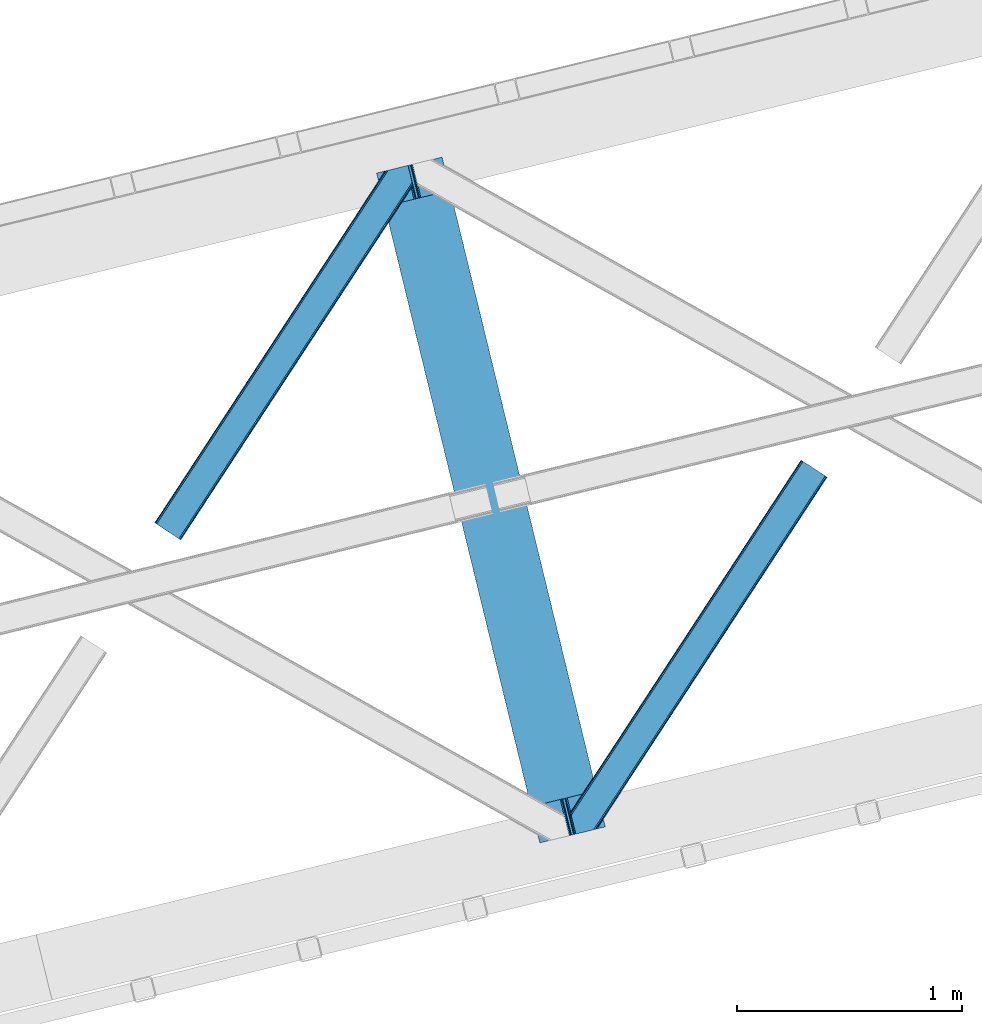
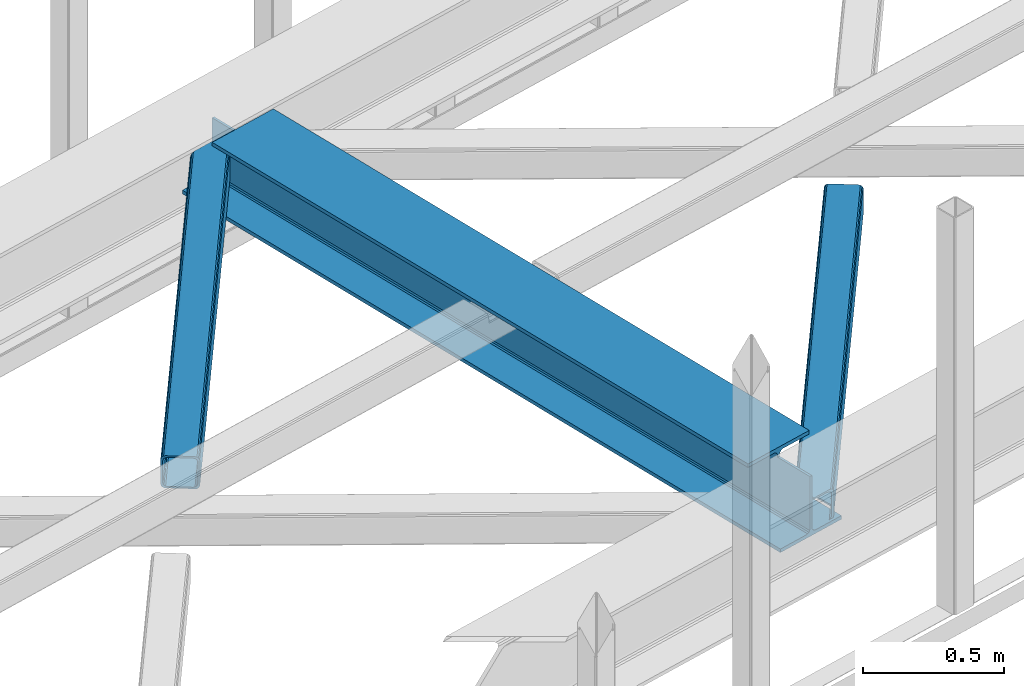
# One storey, part 31 of 67: 2 members, 1 beam.
"""IFC4 building model written with IfcOpenShell, lengths in millimetres."""

from ifc_helpers import new_model, entity, si_unit, converted_unit, derived_unit, direction, frame, origin, place, context, subcontext, project, spatial, triangles, polygons, material, type_object, element, save


model = new_model("IFC4")

# Units and contexts
model_context = context("Model", 3, precision=0.01, world=origin(), true_north=direction((6.12303176911189e-17, 1.0)))
plan_context = context("Plan", 3, precision=0.01, world=origin(), true_north=direction((6.12303176911189e-17, 1.0)))
body_context = subcontext(model_context, "Body", "Model", "MODEL_VIEW")
ifc_project = project(units=[si_unit("LENGTHUNIT", "METRE", prefix="MILLI"), si_unit("AREAUNIT", "SQUARE_METRE"), si_unit("VOLUMEUNIT", "CUBIC_METRE"), converted_unit("PLANEANGLEUNIT", "DEGREE", entity("IfcRatioMeasure", 0.0174532925199433), si_unit("PLANEANGLEUNIT", "RADIAN"), dimensions=[0, 0, 0, 0, 0, 0, 0]), si_unit("MASSUNIT", "GRAM", prefix="KILO"), derived_unit("MASSDENSITYUNIT", [(si_unit("MASSUNIT", "GRAM", prefix="KILO"), 1), (si_unit("LENGTHUNIT", "METRE"), -3)]), derived_unit("MOMENTOFINERTIAUNIT", [(si_unit("LENGTHUNIT", "METRE"), 4)]), si_unit("TIMEUNIT", "SECOND"), si_unit("FREQUENCYUNIT", "HERTZ"), si_unit("THERMODYNAMICTEMPERATUREUNIT", "DEGREE_CELSIUS"), derived_unit("THERMALTRANSMITTANCEUNIT", [(si_unit("MASSUNIT", "GRAM", prefix="KILO"), 1), (si_unit("THERMODYNAMICTEMPERATUREUNIT", "KELVIN"), -1), (si_unit("TIMEUNIT", "SECOND"), -3)]), derived_unit("VOLUMETRICFLOWRATEUNIT", [(si_unit("LENGTHUNIT", "METRE"), 3), (si_unit("TIMEUNIT", "SECOND"), -1)]), derived_unit("MASSFLOWRATEUNIT", [(si_unit("MASSUNIT", "GRAM", prefix="KILO"), 1), (si_unit("TIMEUNIT", "SECOND"), -1)]), derived_unit("ROTATIONALFREQUENCYUNIT", [(si_unit("TIMEUNIT", "SECOND"), -1)]), si_unit("ELECTRICCURRENTUNIT", "AMPERE"), si_unit("ELECTRICVOLTAGEUNIT", "VOLT"), si_unit("POWERUNIT", "WATT"), si_unit("FORCEUNIT", "NEWTON", prefix="KILO"), si_unit("ILLUMINANCEUNIT", "LUX"), si_unit("LUMINOUSFLUXUNIT", "LUMEN"), si_unit("LUMINOUSINTENSITYUNIT", "CANDELA"), derived_unit("USERDEFINED", [(si_unit("MASSUNIT", "GRAM", prefix="KILO"), -1), (si_unit("LENGTHUNIT", "METRE"), -2), (si_unit("TIMEUNIT", "SECOND"), 3), (si_unit("LUMINOUSFLUXUNIT", "LUMEN"), 1)]), derived_unit("LINEARVELOCITYUNIT", [(si_unit("LENGTHUNIT", "METRE"), 1), (si_unit("TIMEUNIT", "SECOND"), -1)]), si_unit("PRESSUREUNIT", "PASCAL"), derived_unit("USERDEFINED", [(si_unit("LENGTHUNIT", "METRE"), -2), (si_unit("MASSUNIT", "GRAM", prefix="KILO"), 1), (si_unit("TIMEUNIT", "SECOND"), -2)]), derived_unit("LINEARFORCEUNIT", [(si_unit("MASSUNIT", "GRAM", prefix="KILO"), 1), (si_unit("LENGTHUNIT", "METRE"), 1), (si_unit("TIMEUNIT", "SECOND"), -2), (si_unit("LENGTHUNIT", "METRE"), -1)]), derived_unit("PLANARFORCEUNIT", [(si_unit("MASSUNIT", "GRAM", prefix="KILO"), 1), (si_unit("LENGTHUNIT", "METRE"), 1), (si_unit("TIMEUNIT", "SECOND"), -2), (si_unit("LENGTHUNIT", "METRE"), -2)])], contexts=[model_context, plan_context])

# Site, building, storey
site_placement = place(None, origin())
site = spatial("IfcSite", under=ifc_project, at=site_placement, CompositionType="ELEMENT")
building_placement = place(site_placement, origin())
building = spatial("IfcBuilding", under=site, at=building_placement, CompositionType="ELEMENT")
storey_placement = place(building_placement, frame((0.0, 0.0, 19800.0)))
storey = spatial("IfcBuildingStorey", under=building, at=storey_placement, CompositionType="ELEMENT", Elevation=19800.0)

# Beam
ifc_material = material(Name="Metal painted (White)")
beam_type = type_object("IfcBeamType", PredefinedType="BEAM")
beam_placement = place(storey_placement, frame((-39874.8174225065, 8075.02059865561, 3807.02022389142)))
element("IfcBeam", 1, at=beam_placement, inside=storey, type_object=beam_type, material=ifc_material, ObjectType="Steel Beam", PredefinedType="BEAM", context=body_context, shape_type="Tessellation", body=[
    polygons([(1018.16648378329, 71.0478278971021, 15.5000000000008), (1018.16648378329, 71.0478278971021, 0.0), (291.465617442446, 3052.25531830421, 0.0), (291.465617442446, 3052.25531830421, 15.5000000000008), (894.779372399329, 40.9709140873291, 15.5000000000008), (168.078506058474, 3022.17840449444, 15.5000000000008), (888.087028625371, 39.3395844888243, 16.8701684147984), (161.386162284528, 3020.54707489593, 16.8701684147984), (882.413533524751, 37.9566100336508, 20.7720779386434), (155.712667183895, 3019.16410044076, 20.7720779386434), (878.622625296176, 37.0325360459151, 26.6116982174294), (151.921758955329, 3018.24002645303, 26.6116982174294), (877.291435352788, 36.7080444135018, 33.500000000001), (150.590569011932, 3017.91553482061, 33.500000000001), (140.875048430514, 3015.54727389071, 33.500000000001), (140.875048430514, 3015.54727389071, 259.000000000002), (150.590569011932, 3017.91553482061, 259.000000000002), (8.66293703438714e-12, 2981.20749040711, 0.0), (8.66293703438714e-12, 2981.20749040711, 15.4999999999965), (123.387111383972, 3011.28440421689, 15.5000000000008), (130.079455157926, 3012.91573381539, 16.8701684147984), (135.752950258551, 3014.29870827056, 20.7720779386434), (139.543858487117, 3015.22278225829, 26.6116982174294), (877.291435352783, 36.7080444135018, 259.000000000002), (867.575914771365, 34.3397834835981, 259.000000000002), (867.575914771365, 34.339783483597, 33.500000000001), (866.244724827968, 34.0152918511827, 26.6116982174294), (862.453816599397, 33.0912178634492, 20.7720779386434), (856.780321498782, 31.7082434082767, 16.8701684147984), (850.087977724828, 30.0769138097719, 15.5000000000008), (726.700866340855, 0.0, 15.4999999999965), (726.700866340855, 0.0, 0.0), (838.124523615921, 197.385937999179, 259.069791973884), (186.469722099971, 2870.72539801218, 259.000000000002), (186.69311520182, 2869.80895360721, 259.617303331124), (186.705504045446, 2869.75812937344, 266.500003008253), (837.979344808156, 197.981416001702, 266.500002998871), (837.979694928899, 197.979979696968, 260.000004007589), (828.499586345876, 194.64586594443, 259.006343171919), (828.276216326111, 195.56231748191, 259.617303331124), (828.263827482486, 195.613141715684, 266.500003008253), (176.989986719784, 2867.38985508742, 266.500002998871), (176.989636599032, 2867.39129139215, 260.000004007589), (176.844830940696, 2867.98534020594, 259.07612046749), (176.754201518561, 2868.35713708228, 259.000000000002), (839.310832678066, 198.304685446387, 273.388305639783), (843.10110926677, 199.231350618301, 279.227924098781), (848.774180214309, 200.616065081978, 283.129832400615), (855.466371895434, 202.248018612792, 284.500000377228), (978.853400583269, 232.3252716679, 284.500000138971), (978.851730776613, 232.332121736634, 299.999995328161), (687.386308679356, 161.283492472592, 299.999995890962), (687.387978486008, 161.27664240386, 284.500000701776), (810.775007173852, 191.353895458971, 284.500000463519), (817.467494069982, 192.984637925549, 283.129832461069), (823.141405718751, 194.365903570074, 279.227924137322), (826.932940505742, 195.28740721937, 273.388305663684), (175.658498849857, 2867.06658564273, 273.388305639788), (171.868222261161, 2866.13992047082, 279.227924098781), (166.195151313631, 2864.75520600714, 283.129832400619), (159.502959632506, 2863.12325247633, 284.500000377228), (36.115930944662, 2833.04599942122, 284.500000138971), (36.1176007513137, 2833.03914935249, 299.999995328161), (327.583022848575, 2904.08777861653, 299.999995890962), (327.581353041924, 2904.09462868526, 284.500000701776), (204.19432435408, 2874.01737563015, 284.500000463519), (197.501837457932, 2872.38663316357, 283.129832461065), (191.827925809181, 2871.00536751905, 279.227924137322), (188.03639102218, 2870.08386386975, 273.388305663684)], [[[1, 2, 3, 4]], [[5, 1, 4, 6]], [[7, 5, 6, 8]], [[9, 7, 8, 10]], [[11, 9, 10, 12]], [[13, 11, 12, 14]], [[15, 16, 17, 14, 12, 10, 8, 6, 4, 3, 18, 19, 20, 21, 22, 23]], [[13, 24, 25, 26, 27, 28, 29, 30, 31, 32, 2, 1, 5, 7, 9, 11]], [[2, 32, 18, 3]], [[32, 31, 19, 18]], [[31, 30, 20, 19]], [[27, 26, 15, 23]], [[28, 27, 23, 22]], [[29, 28, 22, 21]], [[30, 29, 21, 20]], [[33, 24, 13, 14, 17, 34, 35, 36, 37, 38]], [[25, 39, 40, 41, 42, 43, 44, 16, 15, 26]], [[39, 25, 24, 33]], [[45, 34, 17, 16]], [[41, 40, 38, 37, 46, 47, 48, 49, 50, 51, 52, 53, 54, 55, 56, 57]], [[42, 58, 59, 60, 61, 62, 63, 64, 65, 66, 67, 68, 69, 36, 35, 43]], [[46, 37, 36, 69]], [[47, 46, 69, 68]], [[48, 47, 68, 67]], [[49, 48, 67, 66]], [[50, 49, 66, 65]], [[51, 50, 65, 64]], [[52, 51, 64, 63]], [[53, 52, 63, 62]], [[54, 53, 62, 61]], [[55, 54, 61, 60]], [[56, 55, 60, 59]], [[57, 56, 59, 58]], [[41, 57, 58, 42]]], closed=False),
])

# Members
member_type_1 = type_object("IfcMemberType", PredefinedType="BRACE")
member_1_placement = place(storey_placement, frame((-40863.0220458984, 9423.02541046143, 3823.99987792968)))
element("IfcMember", 2, at=member_1_placement, inside=storey, type_object=member_type_1, ObjectType="Steel Horizontal Brace", PredefinedType="BRACE", context=body_context, shape_type="Tessellation", body=[
    triangles([(994.776489257813, 1564.02720794678, 0.0), (1028.82557373047, 1424.34736175537, 0.0), (14.6409667968765, 67.1040435791001, 0.0), (102.486767578128, 9.58604278564417, 0.0), (1.1162109375, 75.9604797363281, 10.8039916992202), (0.0, 76.6900863647461, 17.5012573242202), (1025.02580566407, 1642.17825164795, 17.5012573242202), (4.28811035156104, 73.8821182250977, 5.12526855468968), (990.47907714844, 1585.87703704834, 9.49942016601563), (990.041894531249, 1584.44689178467, 8.74132690429906), (989.90701904297, 1583.99226837158, 8.49948120117188), (990.762780761717, 1580.48783111572, 5.12526855468968), (1027.30938720703, 1642.73519439697, 10.8691040039084), (1027.77912597657, 1642.8503036499, 9.49942016601563), (992.604528808595, 1572.9359664917, 1.33247680664135), (9.03665771484521, 70.7724243164048, 1.33247680664135), (1025.02580566407, 1642.17825164795, 122.499499511719), (0.0, 76.6900863647461, 122.499499511719), (1026.92336425781, 1642.64101409912, 129.196765136719), (1.1162109375, 75.9604797363281, 129.196765136719), (1032.31838378906, 1643.95605010986, 134.87548828125), (4.28811035156104, 73.8821182250977, 134.87548828125), (1040.39230957031, 1645.92453460693, 138.668280029298), (9.03665771484521, 70.7724243164048, 138.668280029298), (1049.91730957032, 1648.24648590088, 140.00075683594), (14.6409667968765, 67.1040435791001, 140.00075683594), (994.874157714847, 1567.85139312744, 9.49942016601563), (994.762536621092, 1567.00725860596, 9.2947814941399), (994.650915527345, 1566.15033416748, 9.08781738281323), (994.539294433598, 1565.30619964599, 8.8831787109375), (994.748583984379, 1564.14464263916, 8.49948120117188), (1047.05701904297, 1647.54769134521, 9.49942016601563), (14.892114257811, 66.9377746582031, 8.3320495605476), (20.4964233398423, 63.2693939208984, 6.99957275390625), (997.046118164064, 1554.71498565674, 6.99957275390625), (10.1435668945342, 70.0474685668942, 12.1248413085959), (1042.27591552735, 1646.3826461792, 12.1248413085959), (1036.8808959961, 1645.06761016846, 17.8035644531265), (1034.98333740234, 1644.60601043701, 24.5008300781265), (6.97166748047312, 72.1258300781246, 17.8035644531265), (5.85545654297312, 72.8560180664063, 24.5008300781265), (1026.55129394531, 1433.65958404541, 6.99957275390625), (96.6313110351548, 13.4206924438477, 6.99957275390625), (1028.71860351563, 1424.77640533447, 8.41343994140698), (1032.83463134766, 1407.88673858643, 5.12526855468968), (1033.6903930664, 1404.38230133057, 8.49948120117188), (1030.99288330078, 1415.43860321045, 1.33247680664135), (1034.98333740234, 1644.60601043701, 115.499926757813), (5.85545654297312, 72.8560180664063, 115.499926757813), (1050.3498413086, 1648.35113067627, 131.668707275392), (1059.87484130859, 1650.67308197021, 133.001184082033), (20.4964233398423, 63.2693939208984, 133.001184082033), (14.892114257811, 66.9377746582031, 131.668707275392), (1042.27591552735, 1646.3826461792, 127.873590087893), (10.1435668945342, 70.0474685668942, 127.873590087893), (1036.8808959961, 1645.06761016846, 122.197192382813), (6.97166748047312, 72.1258300781246, 122.197192382813), (1128.10788574219, 1667.30578765869, 140.00075683594), (1128.10788574219, 1667.30578765869, 133.001184082033), (1144.33015136719, 1600.75868682861, 140.00075683594), (102.486767578128, 9.58604278564417, 140.00075683594), (1142.06052246094, 1610.06974639893, 133.001184082033), (96.6313110351548, 13.4206924438477, 133.001184082033), (1146.50211181641, 1591.84876556396, 138.668280029298), (108.091076660159, 5.91766204833948, 138.668280029298), (1148.34385986329, 1584.29690093994, 134.87548828125), (112.839624023436, 2.80738677978479, 134.87548828125), (1149.57169189453, 1579.25069732666, 129.196765136719), (116.011523437504, 0.729606628417969, 129.196765136719), (1150.00422363282, 1577.47871246338, 122.499499511719), (117.127734375004, 0.0, 122.499499511719), (1150.00422363282, 1577.47871246338, 17.5012573242202), (117.127734375004, 0.0, 17.5012573242202), (106.98416748047, 6.64203643798828, 127.873590087893), (110.156066894531, 4.56367492675781, 122.197192382813), (111.272277832031, 3.83464965820167, 115.499926757813), (102.230969238284, 9.75173034667932, 131.668707275392), (116.011523437504, 0.729606628417969, 10.8039916992202), (106.98416748047, 6.64203643798828, 12.1248413085959), (112.839624023436, 2.80738677978479, 5.12526855468968), (111.272277832031, 3.83464965820167, 24.5008300781265), (110.156066894531, 4.56367492675781, 17.8035644531265), (108.091076660159, 5.91766204833948, 1.33247680664135), (102.230969238284, 9.75173034667932, 8.3320495605476), (1147.30206298828, 1588.56175689697, 122.197192382813), (1147.73459472656, 1586.78977203369, 115.499926757813), (1146.07423095703, 1593.60912322998, 127.873590087893), (1144.23248291016, 1601.160987854, 131.668707275392), (1147.73459472656, 1586.78977203369, 24.5008300781265), (1147.21369628907, 1588.92452545166, 17.8686767578147), (1149.994921875, 1577.51591949463, 16.5013183593765), (1147.10672607422, 1589.36519622803, 16.5013183593765), (1145.27427978516, 1573.10804901123, 10.8714294433594), (1034.62056884765, 1404.78809051514, 9.49942016601563), (1144.12551269531, 1572.03369598389, 9.49942016601563), (1142.79071044922, 1588.5978012085, 12.1248413085959), (1030.22548828125, 1422.81373443603, 9.49942016601563), (1029.19764404297, 1423.67182159424, 8.80643920898365), (1139.7304321289, 1590.06050262451, 9.49942016601563)], [[1, 2, 3], [4, 3, 2], [5, 6, 7], [8, 9, 10], [11, 12, 8], [5, 13, 9], [9, 8, 5], [13, 14, 9], [15, 1, 16], [3, 16, 1], [12, 15, 8], [16, 8, 15], [7, 13, 5], [17, 7, 6], [6, 18, 17], [19, 17, 20], [18, 20, 17], [21, 19, 22], [20, 22, 19], [23, 21, 24], [22, 24, 21], [25, 23, 26], [24, 26, 23], [27, 28, 9], [28, 29, 10], [29, 30, 10], [30, 31, 11], [14, 32, 27], [27, 9, 14], [33, 34, 35], [36, 33, 31], [31, 30, 36], [28, 36, 29], [28, 27, 36], [36, 30, 29], [32, 37, 27], [36, 27, 37], [35, 31, 33], [38, 39, 40], [41, 40, 39], [37, 38, 36], [40, 36, 38], [42, 35, 34], [34, 43, 42], [1, 35, 42], [31, 12, 11], [1, 31, 35], [31, 15, 12], [31, 1, 15], [2, 1, 42], [44, 2, 42], [45, 44, 46], [44, 47, 2], [44, 45, 47], [39, 48, 49], [49, 41, 39], [50, 51, 52], [52, 53, 50], [54, 50, 53], [53, 55, 54], [56, 54, 55], [55, 57, 56], [48, 56, 57], [57, 49, 48], [56, 17, 19], [50, 23, 25], [58, 51, 25], [51, 58, 59], [51, 50, 25], [54, 23, 50], [54, 56, 21], [21, 23, 54], [19, 21, 56], [39, 7, 17], [37, 14, 38], [56, 48, 17], [37, 32, 14], [39, 38, 7], [48, 39, 17], [13, 7, 38], [38, 14, 13], [60, 25, 61], [25, 60, 58], [26, 61, 25], [51, 62, 63], [51, 59, 62], [63, 52, 51], [64, 60, 61], [61, 65, 64], [66, 64, 65], [65, 67, 66], [68, 66, 67], [67, 69, 68], [70, 68, 69], [69, 71, 70], [72, 70, 71], [71, 73, 72], [69, 74, 75], [76, 73, 71], [69, 75, 71], [69, 67, 74], [75, 76, 71], [74, 67, 65], [63, 61, 26], [61, 77, 65], [77, 61, 63], [77, 74, 65], [78, 79, 80], [81, 73, 76], [73, 82, 78], [82, 73, 81], [78, 82, 79], [4, 43, 3], [83, 80, 79], [79, 84, 83], [84, 43, 4], [4, 83, 84], [55, 24, 22], [26, 52, 63], [26, 53, 52], [53, 26, 24], [55, 53, 24], [49, 18, 6], [20, 57, 55], [22, 20, 55], [57, 20, 18], [49, 57, 18], [16, 36, 8], [3, 43, 34], [34, 33, 3], [33, 36, 16], [16, 3, 33], [5, 8, 36], [6, 41, 49], [40, 6, 5], [6, 40, 41], [40, 5, 36], [85, 86, 75], [76, 75, 86], [87, 85, 74], [75, 74, 85], [88, 87, 77], [74, 77, 87], [62, 88, 63], [77, 63, 88], [86, 89, 81], [81, 76, 86], [90, 91, 92], [70, 72, 89], [72, 90, 89], [89, 86, 70], [72, 91, 90], [85, 70, 86], [68, 70, 85], [66, 85, 87], [85, 66, 68], [87, 64, 66], [88, 64, 87], [88, 62, 60], [88, 60, 64], [62, 58, 60], [62, 59, 58], [73, 78, 93], [93, 72, 73], [94, 93, 78], [94, 95, 93], [80, 45, 46], [46, 78, 80], [46, 94, 78], [47, 45, 83], [80, 83, 45], [2, 47, 4], [83, 4, 47], [93, 91, 72], [82, 81, 89], [82, 92, 96], [82, 90, 92], [84, 97, 98], [79, 96, 97], [97, 84, 79], [96, 99, 97], [43, 84, 44], [44, 42, 43], [96, 79, 82], [89, 90, 82], [96, 91, 93], [96, 92, 91], [96, 95, 99], [93, 95, 96], [99, 95, 97], [94, 97, 95]]),
])
member_type_2 = type_object("IfcMemberType", PredefinedType="BRACE")
member_2_placement = place(storey_placement, frame((-39011.7001647949, 8114.09658508301, 3823.99987792968)))
element("IfcMember", 3, at=member_2_placement, inside=storey, type_object=member_type_2, ObjectType="Steel Horizontal Brace", PredefinedType="BRACE", context=body_context, shape_type="Tessellation", body=[
    triangles([(109.770043945311, 259.950411987305, 7.52047119140843), (115.030187988283, 238.366264343263, 7.77626953125218), (114.216284179689, 239.946981811524, 8.3320495605476), (108.809637451173, 259.66263885498, 8.52041015625218), (113.637249755855, 239.860359191895, 8.52041015625218), (112.209429931638, 237.677934265136, 8.52041015625218), (91.0363037109346, 232.516621398926, 8.52041015625218), (109.537499999999, 237.026811218261, 9.49942016601563), (90.2619323730469, 232.328260803223, 9.49942016601563), (5.02062377929542, 77.405158996582, 9.49942016601563), (0.62786865234375, 95.4313842773436, 9.49942016601563), (1046.62448730469, 1651.75382995606, 6.99957275390625), (1041.02017822266, 1655.42221069336, 8.3320495605476), (116.702178955078, 231.514938354493, 6.99957275390625), (1036.27395629883, 1658.53248596192, 12.1248413085959), (3.93231811523583, 81.8758163452158, 12.1248413085959), (1033.09740600586, 1660.61026611328, 17.8035644531265), (2.70216064452688, 86.922019958497, 17.8035644531265), (1031.98352050781, 1661.34045410156, 24.5008300781265), (2.26962890625146, 88.6940048217775, 24.5008300781265), (1122.75704956055, 1601.905128479, 6.99957275390625), (146.20968017578, 110.459536743164, 6.99957275390625), (1031.98352050781, 1661.34045410156, 115.499926757813), (2.26962890625146, 88.6940048217775, 115.499926757813), (1033.09740600586, 1660.61026611328, 122.197192382813), (2.70216064452688, 86.922019958497, 122.197192382813), (1036.27395629883, 1658.53248596192, 127.873590087893), (3.93231811523583, 81.8758163452158, 127.873590087893), (1041.02017822266, 1655.42221069336, 131.668707275392), (5.77174072265188, 74.3233703613287, 131.668707275392), (1046.62448730469, 1651.75382995606, 133.001184082033), (7.94370117187646, 65.4146118164063, 133.001184082033), (1027.24194946289, 1664.44491577149, 10.8039916992202), (0.518572998043965, 95.8720550537118, 10.8691040039084), (0.0, 98.0062271118159, 17.5012573242202), (1035.16472167968, 1659.25686035156, 1.33247680664135), (112.260589599609, 249.735919189453, 1.33247680664135), (110.544415283199, 256.772117614747, 5.59500732422021), (109.077062988283, 259.839953613281, 8.32042236328198), (1030.41384887695, 1662.36713562012, 5.12526855468968), (1040.76670532226, 1655.58847961426, 0.0), (114.430224609372, 240.827160644531, 0.0), (1026.12806396484, 1665.17510375977, 17.5012573242202), (1128.61250610351, 1598.0704788208, 0.0), (148.479309082031, 101.147895812989, 0.0), (150.651269531249, 92.2391372680659, 1.33247680664135), (148.509539794919, 101.029879760742, 8.49948120117188), (152.493017578126, 84.6866912841806, 5.12526855468968), (153.346453857419, 81.1828353881838, 8.49948120117188), (1026.12806396484, 1665.17510375977, 122.499499511719), (0.0, 98.0062271118159, 122.499499511719), (1040.76670532226, 1655.58847961426, 140.00075683594), (1035.16472167968, 1659.25686035156, 138.668280029298), (3.50211181640771, 83.6350112915034, 138.668280029298), (5.674072265625, 74.7262527465818, 140.00075683594), (1030.41384887695, 1662.36713562012, 134.87548828125), (1.66036376952979, 91.1874572753904, 134.87548828125), (1027.24194946289, 1664.44491577149, 129.196765136719), (0.430206298828125, 96.2342422485353, 129.196765136719), (23.8892395019502, 0.0, 140.00075683594), (23.8892395019502, 0.0, 133.001184082033), (1128.61250610351, 1598.0704788208, 140.00075683594), (93.3361633300738, 16.9286178588873, 140.00075683594), (1122.75704956055, 1601.905128479, 133.001184082033), (83.3809570312515, 14.5020217895508, 133.001184082033), (1143.25347290039, 1588.48443603516, 122.499499511719), (1142.13958740234, 1589.21404266358, 129.196765136719), (118.225341796875, 22.9956893920898, 122.499499511719), (116.332434082033, 22.5340896606449, 129.196765136719), (1138.96536254883, 1591.29182281494, 134.87548828125), (110.935089111328, 21.2184722900392, 134.87548828125), (1134.21681518554, 1594.40267944336, 138.668280029298), (102.861163330075, 19.2499877929686, 138.668280029298), (1143.25347290039, 1588.48443603516, 17.5012573242202), (118.225341796875, 22.9956893920898, 17.5012573242202), (1142.13958740234, 1589.21404266358, 10.8039916992202), (1133.10990600586, 1595.12647247315, 12.1248413085959), (1136.28180541992, 1593.04811096192, 17.8035644531265), (1137.39801635742, 1592.31908569336, 24.5008300781265), (1138.96536254883, 1591.29182281494, 5.12526855468968), (1134.21681518554, 1594.40267944336, 1.33247680664135), (1128.35903320312, 1598.2367477417, 8.3320495605476), (1133.10990600586, 1595.12647247315, 127.873590087893), (1137.39801635742, 1592.31908569336, 115.499926757813), (1136.28180541992, 1593.04811096192, 122.197192382813), (1128.35903320312, 1598.2367477417, 131.668707275392), (92.9059570312456, 16.8239730834966, 131.668707275392), (100.979882812499, 18.7918762207037, 127.873590087893), (106.374902343749, 20.1069122314457, 122.197192382813), (108.270135498045, 20.5685119628906, 115.499926757813), (108.270135498045, 20.5685119628906, 24.5008300781265), (100.979882812499, 18.7918762207037, 12.1248413085959), (115.474346923824, 22.3248001098636, 9.49942016601563), (106.374902343749, 20.1069122314457, 17.8035644531265), (96.2011047363267, 17.6268310546875, 9.49942016601563), (115.944085693358, 22.4393280029299, 10.8691040039084), (153.060424804688, 80.2398696899409, 8.99945068359375), (152.776721191403, 79.2974853515634, 9.49942016601563), (148.711853027344, 99.8683227539068, 8.8831787109375), (148.602557373044, 99.023606872558, 9.08781738281323), (148.493261718751, 98.1678451538091, 9.2947814941399), (148.381640624997, 97.3231292724604, 9.49942016601563)], [[1, 2, 3], [4, 5, 6], [6, 7, 4], [7, 6, 8], [8, 9, 7], [9, 8, 10], [10, 11, 9], [12, 13, 3], [3, 2, 12], [2, 14, 12], [15, 16, 8], [8, 13, 15], [8, 5, 13], [16, 10, 8], [8, 6, 5], [15, 17, 18], [18, 16, 15], [17, 19, 20], [20, 18, 17], [21, 12, 14], [14, 22, 21], [19, 23, 24], [24, 20, 19], [23, 25, 24], [26, 24, 25], [25, 27, 26], [28, 26, 27], [27, 29, 28], [30, 28, 29], [29, 31, 30], [32, 30, 31], [33, 34, 35], [36, 37, 38], [33, 4, 9], [33, 1, 39], [9, 34, 33], [9, 11, 34], [4, 7, 9], [40, 38, 1], [1, 33, 40], [38, 40, 36], [36, 41, 37], [42, 37, 41], [35, 43, 33], [41, 44, 42], [45, 42, 44], [14, 42, 22], [37, 2, 38], [2, 37, 42], [38, 2, 1], [42, 14, 2], [22, 42, 45], [46, 47, 45], [47, 46, 48], [45, 47, 22], [48, 49, 47], [50, 43, 35], [35, 51, 50], [52, 53, 54], [54, 55, 52], [53, 56, 57], [57, 54, 53], [56, 58, 59], [59, 57, 56], [58, 50, 51], [51, 59, 58], [28, 57, 26], [30, 32, 55], [32, 60, 55], [32, 61, 60], [54, 30, 55], [28, 54, 57], [16, 11, 10], [28, 30, 54], [51, 35, 20], [24, 26, 51], [24, 51, 20], [57, 59, 26], [26, 59, 51], [35, 18, 20], [18, 11, 16], [11, 18, 34], [35, 34, 18], [62, 55, 63], [62, 52, 55], [55, 60, 63], [64, 32, 31], [32, 64, 65], [61, 32, 65], [66, 67, 68], [69, 68, 67], [67, 70, 69], [71, 69, 70], [70, 72, 71], [73, 71, 72], [72, 62, 73], [63, 73, 62], [74, 66, 68], [68, 75, 74], [76, 77, 78], [79, 66, 74], [76, 78, 74], [76, 80, 77], [78, 79, 74], [77, 80, 81], [21, 44, 41], [44, 82, 81], [82, 44, 21], [82, 77, 81], [67, 83, 70], [84, 66, 79], [66, 85, 67], [85, 66, 84], [67, 85, 83], [62, 64, 52], [72, 70, 83], [83, 86, 72], [86, 64, 62], [62, 72, 86], [15, 36, 40], [41, 12, 21], [41, 13, 12], [13, 41, 36], [15, 13, 36], [19, 43, 50], [33, 17, 15], [40, 33, 15], [17, 33, 43], [19, 17, 43], [53, 27, 56], [52, 64, 31], [31, 29, 52], [29, 27, 53], [53, 52, 29], [58, 56, 27], [50, 23, 19], [25, 50, 58], [50, 25, 23], [25, 58, 27], [64, 86, 87], [87, 65, 64], [86, 83, 88], [88, 87, 86], [83, 85, 89], [89, 88, 83], [85, 84, 90], [90, 89, 85], [84, 79, 91], [91, 90, 84], [89, 68, 69], [87, 73, 63], [60, 65, 63], [65, 60, 61], [65, 87, 63], [88, 73, 87], [88, 89, 71], [71, 73, 88], [69, 71, 89], [91, 75, 68], [92, 93, 94], [89, 90, 68], [92, 95, 93], [91, 94, 75], [90, 91, 68], [96, 75, 94], [94, 93, 96], [76, 74, 75], [49, 80, 97], [98, 97, 80], [49, 48, 80], [76, 96, 98], [98, 80, 76], [96, 93, 98], [44, 81, 45], [46, 45, 81], [81, 80, 46], [48, 46, 80], [75, 96, 76], [82, 21, 22], [77, 82, 47], [47, 99, 77], [77, 100, 101], [100, 77, 99], [101, 102, 77], [77, 102, 92], [95, 92, 102], [22, 47, 82], [79, 78, 91], [94, 91, 78], [78, 77, 94], [92, 94, 77], [102, 101, 98], [101, 100, 97], [100, 99, 49], [99, 47, 49], [102, 98, 93], [93, 95, 102]]),
])

save(model, "model.ifc")
